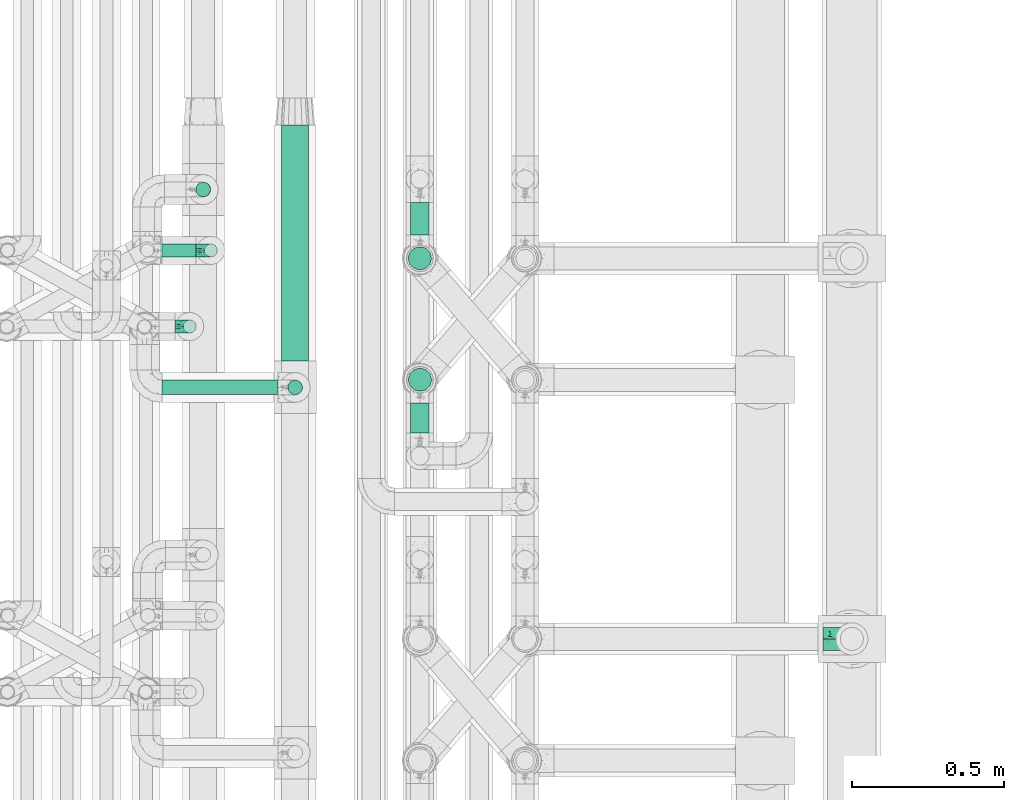
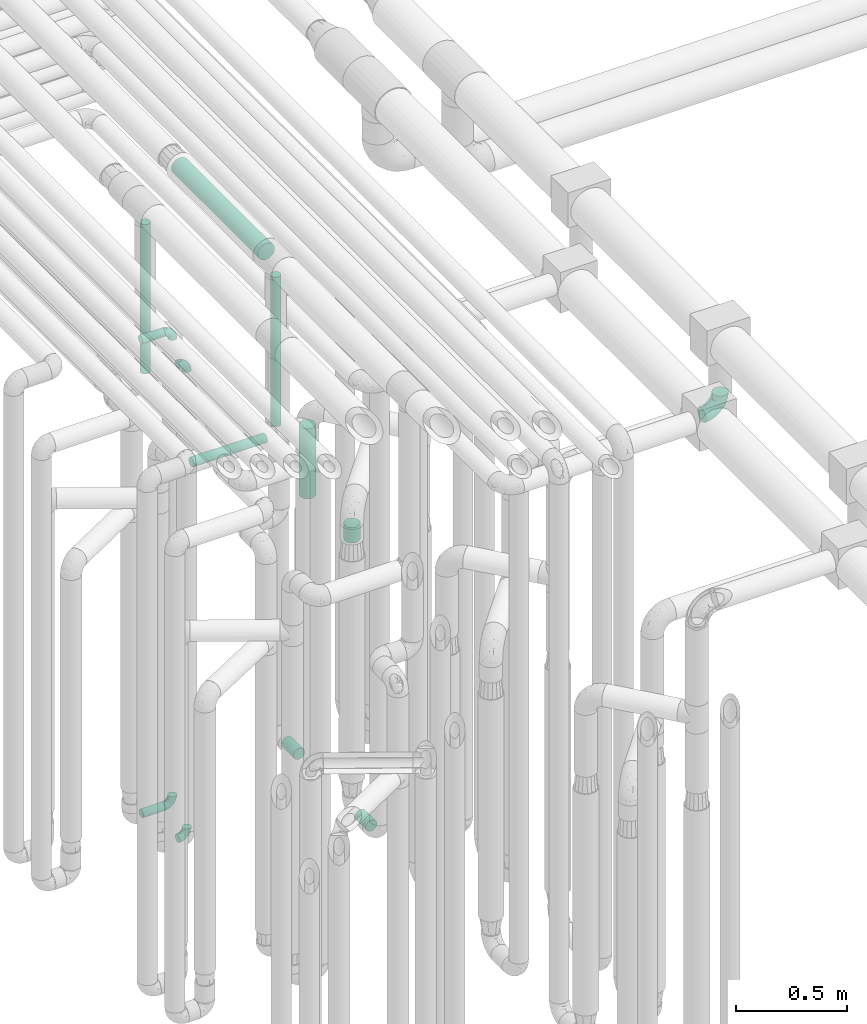
# One storey, part 622 of 827: 10 flow segments, 5 flow fittings.
"""IFC2X3 building model written with IfcOpenShell, lengths in millimetres."""

from ifc_helpers import new_model, entity, si_unit, converted_unit, derived_unit, direction, frame, origin, origin_2d_with_axis, place, context, subcontext, project, spatial, polyline, circle, outline, extrude, faceted_brep, source, transform, mapped, material, type_object, type_shapes, element, save


model = new_model("IFC2X3")

# Units and contexts
model_context = context("Model", 3, precision=0.01, world=origin(), true_north=direction((6.12303176911189e-17, 1.0)))
body_context = subcontext(model_context, "Body", "Model", "MODEL_VIEW")
ifc_project = project(units=[si_unit("LENGTHUNIT", "METRE", prefix="MILLI"), si_unit("AREAUNIT", "SQUARE_METRE"), si_unit("VOLUMEUNIT", "CUBIC_METRE"), converted_unit("PLANEANGLEUNIT", "DEGREE", entity("IfcRatioMeasure", 0.0174532925199433), si_unit("PLANEANGLEUNIT", "RADIAN"), dimensions=[0, 0, 0, 0, 0, 0, 0]), si_unit("MASSUNIT", "GRAM", prefix="KILO"), derived_unit("MASSDENSITYUNIT", [(si_unit("MASSUNIT", "GRAM", prefix="KILO"), 1), (si_unit("LENGTHUNIT", "METRE"), -3)]), derived_unit("MOMENTOFINERTIAUNIT", [(si_unit("LENGTHUNIT", "METRE"), 4)]), si_unit("TIMEUNIT", "SECOND"), si_unit("FREQUENCYUNIT", "HERTZ"), si_unit("THERMODYNAMICTEMPERATUREUNIT", "DEGREE_CELSIUS"), derived_unit("THERMALTRANSMITTANCEUNIT", [(si_unit("MASSUNIT", "GRAM", prefix="KILO"), 1), (si_unit("THERMODYNAMICTEMPERATUREUNIT", "KELVIN"), -1), (si_unit("TIMEUNIT", "SECOND"), -3)]), derived_unit("VOLUMETRICFLOWRATEUNIT", [(si_unit("LENGTHUNIT", "METRE"), 3), (si_unit("TIMEUNIT", "SECOND"), -1)]), derived_unit("MASSFLOWRATEUNIT", [(si_unit("MASSUNIT", "GRAM", prefix="KILO"), 1), (si_unit("TIMEUNIT", "SECOND"), -1)]), derived_unit("ROTATIONALFREQUENCYUNIT", [(si_unit("TIMEUNIT", "SECOND"), -1)]), si_unit("ELECTRICCURRENTUNIT", "AMPERE"), si_unit("ELECTRICVOLTAGEUNIT", "VOLT"), si_unit("POWERUNIT", "WATT"), si_unit("FORCEUNIT", "NEWTON", prefix="KILO"), si_unit("ILLUMINANCEUNIT", "LUX"), si_unit("LUMINOUSFLUXUNIT", "LUMEN"), si_unit("LUMINOUSINTENSITYUNIT", "CANDELA"), derived_unit("USERDEFINED", [(si_unit("MASSUNIT", "GRAM", prefix="KILO"), -1), (si_unit("LENGTHUNIT", "METRE"), -2), (si_unit("TIMEUNIT", "SECOND"), 3), (si_unit("LUMINOUSFLUXUNIT", "LUMEN"), 1)]), derived_unit("LINEARVELOCITYUNIT", [(si_unit("LENGTHUNIT", "METRE"), 1), (si_unit("TIMEUNIT", "SECOND"), -1)]), si_unit("PRESSUREUNIT", "PASCAL"), derived_unit("USERDEFINED", [(si_unit("LENGTHUNIT", "METRE"), -2), (si_unit("MASSUNIT", "GRAM", prefix="KILO"), 1), (si_unit("TIMEUNIT", "SECOND"), -2)]), derived_unit("LINEARFORCEUNIT", [(si_unit("MASSUNIT", "GRAM", prefix="KILO"), 1), (si_unit("LENGTHUNIT", "METRE"), 1), (si_unit("TIMEUNIT", "SECOND"), -2), (si_unit("LENGTHUNIT", "METRE"), -1)]), derived_unit("PLANARFORCEUNIT", [(si_unit("MASSUNIT", "GRAM", prefix="KILO"), 1), (si_unit("LENGTHUNIT", "METRE"), 1), (si_unit("TIMEUNIT", "SECOND"), -2), (si_unit("LENGTHUNIT", "METRE"), -2)])], contexts=[model_context])

# Site, building, storey
site_placement = place(None, origin())
site = spatial("IfcSite", under=ifc_project, at=site_placement, CompositionType="ELEMENT")
building_placement = place(site_placement, origin())
building = spatial("IfcBuilding", under=site, at=building_placement, CompositionType="ELEMENT")
storey_placement = place(building_placement, frame((0.0, 0.0, 28200.0)))
storey = spatial("IfcBuildingStorey", under=building, at=storey_placement, Name="08", CompositionType="ELEMENT", Elevation=28200.0)

# Flow segments
pipe_segment_type = type_object("IfcPipeSegmentType", PredefinedType="NOTDEFINED")
flow_segment_1_placement = place(storey_placement, frame((35782.14, 12983.46, 377.25)))
element("IfcFlowSegment", 1, at=flow_segment_1_placement, inside=storey, type_object=pipe_segment_type, context=body_context, shape_type="SweptSolid", body=[
    extrude(circle(Radius=21.15, at=origin_2d_with_axis()), frame((0.0, 22.75, 22.75), z_axis=(1.0, 0.0, 0.0), x_axis=(0.0, 1.0, 0.0)), (0.0, 0.0, 1.0), 112.906910281965),
])
flow_segment_2_placement = place(storey_placement, frame((35778.03, 12983.46, 2977.25)))
element("IfcFlowSegment", 2, at=flow_segment_2_placement, inside=storey, type_object=pipe_segment_type, context=body_context, shape_type="SweptSolid", body=[
    extrude(circle(Radius=21.15, at=origin_2d_with_axis()), frame((0.0, 22.75, 22.75), z_axis=(1.0, 0.0, 0.0), x_axis=(0.0, -1.0, 0.0)), (0.0, 0.0, 1.0), 117.013860377989),
])
flow_segment_3_placement = place(storey_placement, frame((36598.05, 13056.2, 368.4)))
element("IfcFlowSegment", 3, at=flow_segment_3_placement, inside=storey, type_object=pipe_segment_type, context=body_context, shape_type="SweptSolid", body=[
    extrude(circle(Radius=30.0, at=origin_2d_with_axis()), frame((31.6, 0.0, 31.6), z_axis=(0.0, 1.0, 0.0), x_axis=(-1.0, 0.0, 0.0)), (0.0, 0.0, 1.0), 108.00000000001),
])
flow_segment_4_placement = place(storey_placement, frame((36598.05, 12407.17, 368.4)))
element("IfcFlowSegment", 4, at=flow_segment_4_placement, inside=storey, type_object=pipe_segment_type, context=body_context, shape_type="SweptSolid", body=[
    extrude(circle(Radius=30.0, at=origin_2d_with_axis()), frame((31.6, 0.0, 31.6), z_axis=(0.0, 1.0, 0.0), x_axis=(1.0, 0.0, 0.0)), (0.0, 0.0, 1.0), 97.9999910000113),
])
flow_segment_5_placement = place(storey_placement, frame((36590.3, 12940.86, 1870.0)))
element("IfcFlowSegment", 5, at=flow_segment_5_placement, inside=storey, type_object=pipe_segment_type, context=body_context, shape_type="SweptSolid", body=[
    extrude(circle(Radius=37.75, at=origin_2d_with_axis()), frame((39.35, 39.35, 0.0)), (0.0, 0.0, 1.0), 384.999999999995),
])
flow_segment_6_placement = place(storey_placement, frame((36590.58, 12541.83, 1869.99)))
element("IfcFlowSegment", 6, at=flow_segment_6_placement, inside=storey, type_object=pipe_segment_type, context=body_context, shape_type="SweptSolid", body=[
    extrude(circle(Radius=37.75, at=origin_2d_with_axis()), frame((39.36, 39.35, 0.01), z_axis=(-0.000210996047409579, 0.0, 0.999999977740334), x_axis=(0.999999977740334, 0.0, 0.000210996047409579)), (0.0, 0.0, 1.0), 85.0000036990977),
])
flow_segment_7_placement = place(storey_placement, frame((35892.47, 13180.49, 2657.02)))
element("IfcFlowSegment", 7, at=flow_segment_7_placement, inside=storey, type_object=pipe_segment_type, context=body_context, shape_type="SweptSolid", body=[
    extrude(circle(Radius=24.0, at=origin_2d_with_axis()), frame((26.06, 25.6, 0.01), z_axis=(-0.000562863572107548, 0.0, 0.999999841592287), x_axis=(0.999999841592287, 0.0, 0.000562863572107548)), (0.0, 0.0, 1.0), 819.969793896105),
])
flow_segment_8_placement = place(storey_placement, frame((35782.03, 12530.49, 2574.4)))
element("IfcFlowSegment", 8, at=flow_segment_8_placement, inside=storey, type_object=pipe_segment_type, context=body_context, shape_type="SweptSolid", body=[
    extrude(circle(Radius=24.0, at=origin_2d_with_axis()), frame((0.0, 25.6, 25.6), z_axis=(1.0, 0.0, 0.0), x_axis=(0.0, -1.0, 0.0)), (0.0, 0.0, 1.0), 380.999999885415),
])
flow_segment_9_placement = place(storey_placement, frame((36194.44, 12530.49, 2657.0)))
element("IfcFlowSegment", 9, at=flow_segment_9_placement, inside=storey, type_object=pipe_segment_type, context=body_context, shape_type="SweptSolid", body=[
    extrude(outline(polyline([(-3.13, -23.79), (3.13, -23.79), (9.18, -22.17), (14.61, -19.04), (19.04, -14.61), (22.17, -9.18), (23.79, -3.13), (23.79, 3.13), (22.17, 9.18), (19.04, 14.61), (14.61, 19.04), (9.18, 22.17), (3.13, 23.79), (-3.13, 23.79), (-9.18, 22.17), (-14.61, 19.04), (-19.04, 14.61), (-22.17, 9.18), (-23.79, 3.13), (-23.79, -3.13), (-22.17, -9.18), (-19.04, -14.61), (-14.61, -19.04), (-9.18, -22.17), (-3.13, -23.79)])), frame((25.6, 25.6, 0.0), z_axis=(0.0, -8.11528883373535e-09, 1.0), x_axis=(-0.130526192219642, 0.991444861373864, 8.04589959840434e-09)), (0.0, 0.0, 1.0), 820.00007854167),
])
flow_segment_10_placement = place(storey_placement, frame((36174.19, 12642.08, 3504.15)))
element("IfcFlowSegment", 10, at=flow_segment_10_placement, inside=storey, type_object=pipe_segment_type, context=body_context, shape_type="SweptSolid", body=[
    extrude(circle(Radius=44.25, at=origin_2d_with_axis()), frame((45.85, 0.0, 45.85), z_axis=(0.0, 1.0, 0.0), x_axis=(-1.0, 0.0, 0.0)), (0.0, 0.0, 1.0), 775.619330449277),
])

# Flow fittings
ifc_material = material()
pipe_fitting_type_1 = type_object("IfcPipeFittingType", Name="ADSK_1", PredefinedType="NOTDEFINED", material=ifc_material)
shared_shape_1 = source(origin(), body_context, "Body", "Brep", [
    faceted_brep([(-48.0, 10.6, -18.36), (-48.0, 5.49, -20.48), (-48.0, 0.0, -21.2), (-48.0, -5.49, -20.48), (-48.0, -10.6, -18.36), (-48.0, -14.99, -14.99), (-48.0, -18.36, -10.6), (-48.0, -20.48, -5.49), (-48.0, -21.2, 0.0), (-48.0, -20.48, 5.49), (-48.0, -18.36, 10.6), (-48.0, -14.99, 14.99), (-48.0, -10.6, 18.36), (-48.0, -5.49, 20.48), (-48.0, 0.0, 21.2), (-48.0, 5.49, 20.48), (-48.0, 10.6, 18.36), (-48.0, 14.99, 14.99), (-48.0, 18.36, 10.6), (-48.0, 20.48, 5.49), (-48.0, 21.2, 0.0), (-48.0, 20.48, -5.49), (-48.0, 18.36, -10.6), (-48.0, 14.99, -14.99), (0.0, 48.0, -21.2), (-5.49, 48.0, -20.48), (-10.6, 48.0, -18.36), (-14.99, 48.0, -14.99), (-18.36, 48.0, -10.6), (-20.48, 48.0, -5.49), (-21.2, 48.0, 0.0), (-20.48, 48.0, 5.49), (-18.36, 48.0, 10.6), (-14.99, 48.0, 14.99), (-10.6, 48.0, 18.36), (-5.49, 48.0, 20.48), (0.0, 48.0, 21.2), (5.49, 48.0, 20.48), (10.6, 48.0, 18.36), (14.99, 48.0, 14.99), (18.36, 48.0, 10.6), (20.48, 48.0, 5.49), (21.2, 48.0, 0.0), (20.48, 48.0, -5.49), (18.36, 48.0, -10.6), (14.99, 48.0, -14.99), (10.6, 48.0, -18.36), (5.49, 48.0, -20.48), (-35.25, -16.22, 12.01), (-34.76, -18.57, 0.0), (-20.87, -12.37, 10.9), (-31.49, -11.78, 15.9), (-37.0, -2.58, 20.86), (-33.89, 3.62, 21.15), (-31.81, -18.14, 6.76), (-5.78, 5.78, 17.67), (-19.42, -4.1, 17.86), (-9.6, -3.39, 13.73), (-35.44, -7.73, 19.13), (11.78, 31.49, 15.9), (-5.93, -5.46, 6.95), (-18.45, -13.78, 5.46), (-10.29, -8.43, 0.0), (-24.6, 0.55, 20.62), (-37.28, 17.94, 13.81), (-33.38, 22.85, 9.59), (-41.46, 20.06, 8.75), (-29.51, 20.45, 15.16), (-15.04, 10.79, 21.13), (-7.08, 16.98, 20.93), (-8.39, 23.51, 21.15), (-40.86, 13.03, 17.26), (-8.05, 41.26, 19.83), (-3.21, 35.97, 21.14), (8.53, 19.66, 14.74), (4.1, 19.42, 17.86), (-37.72, 22.66, 4.78), (-37.07, 8.58, 19.98), (-13.0, 5.43, 19.97), (-3.78, 13.93, 19.7), (3.02, 8.69, 13.43), (-2.27, -0.05, 10.65), (6.22, 6.99, 7.09), (-22.25, 34.6, 9.45), (18.14, 31.81, 6.76), (16.22, 35.25, 12.01), (12.37, 20.87, 10.9), (7.73, 35.44, 19.13), (-21.52, -15.93, 0.0), (2.58, 37.0, 20.86), (18.57, 34.76, 0.0), (13.78, 18.45, 5.46), (15.93, 21.52, 0.0), (-20.03, -8.54, 14.9), (-28.6, 28.6, 5.16), (-24.79, 34.6, 0.0), (-34.6, 24.79, 0.0), (-22.81, 37.41, 4.68), (-23.36, 26.33, 14.79), (-13.68, 37.05, 17.49), (-17.72, 38.12, 13.73), (-26.25, 27.3, 11.24), (-9.71, 32.34, 20.14), (-17.26, 25.6, 18.71), (-26.33, 9.99, 20.77), (-24.06, 6.05, 21.2), (-25.02, 15.46, 19.56), (-24.3, 20.72, 17.57), (-31.95, 15.23, 17.8), (-13.53, 24.7, 20.21), (-17.6, 17.6, 20.6), (-0.55, 24.6, 20.62), (-11.41, -7.48, 10.43), (0.93, -0.93, 0.0), (8.43, 10.29, 0.0), (-11.41, -7.48, -10.43), (-20.1, -8.84, -14.66), (-9.6, -3.39, -13.73), (7.73, 35.44, -19.13), (4.1, 19.42, -17.86), (-0.55, 24.6, -20.62), (-38.12, 17.72, -13.73), (-37.05, 13.68, -17.49), (-32.34, 9.71, -20.14), (-41.26, 8.05, -19.83), (-37.41, 22.81, -4.68), (-23.51, 8.39, -21.15), (-35.97, 3.21, -21.14), (-28.6, 28.6, -5.16), (-31.81, -18.14, -6.76), (-18.45, -13.78, -5.46), (-25.6, 17.26, -18.71), (-19.42, -4.1, -17.86), (-17.94, 37.28, -13.81), (-22.85, 33.38, -9.59), (-20.06, 41.46, -8.75), (-31.49, -11.78, -15.9), (-35.25, -16.22, -12.01), (8.53, 19.66, -14.74), (11.78, 31.49, -15.9), (-9.99, 26.33, -20.77), (-6.05, 24.06, -21.2), (-10.79, 15.04, -21.13), (-37.0, -2.58, -20.86), (-16.98, 7.08, -20.93), (-5.43, 13.0, -19.97), (-13.93, 3.78, -19.7), (-20.87, -12.37, -10.9), (-26.33, 23.36, -14.79), (-22.66, 37.72, -4.78), (13.78, 18.45, -5.46), (18.14, 31.81, -6.76), (-15.46, 25.02, -19.56), (-20.72, 24.3, -17.57), (16.22, 35.25, -12.01), (-13.03, 40.86, -17.26), (-8.58, 37.07, -19.98), (2.58, 37.0, -20.86), (-3.62, 33.89, -21.15), (-34.6, 22.25, -9.45), (6.22, 6.99, -7.09), (-20.45, 29.51, -15.16), (-35.44, -7.73, -19.13), (12.37, 20.87, -10.9), (-27.3, 26.25, -11.24), (-15.23, 31.95, -17.8), (-24.7, 13.53, -20.21), (-24.6, 0.55, -20.62), (-5.78, 5.78, -17.67), (-17.6, 17.6, -20.6), (3.02, 8.69, -13.43), (-5.93, -5.46, -6.95), (-2.27, -0.05, -10.65)], [[[0, 1, 2, 3, 4, 5, 6, 7, 8, 9, 10, 11, 12, 13, 14, 15, 16, 17, 18, 19, 20, 21, 22, 23]], [[24, 25, 26, 27, 28, 29, 30, 31, 32, 33, 34, 35, 36, 37, 38, 39, 40, 41, 42, 43, 44, 45, 46, 47]], [[10, 48, 11]], [[9, 8, 49]], [[48, 50, 51]], [[14, 52, 53]], [[10, 54, 48]], [[9, 54, 10]], [[55, 56, 57]], [[51, 12, 11]], [[51, 58, 12]], [[59, 39, 38]], [[60, 61, 62]], [[58, 56, 63]], [[64, 65, 66]], [[67, 65, 64]], [[68, 69, 70]], [[16, 71, 17]], [[13, 52, 14]], [[35, 72, 73]], [[14, 53, 15]], [[17, 64, 18]], [[74, 59, 75]], [[20, 19, 76]], [[66, 19, 18]], [[77, 15, 53]], [[15, 77, 16]], [[69, 78, 79]], [[80, 81, 82]], [[32, 31, 83]], [[84, 85, 86]], [[59, 87, 75]], [[61, 54, 88]], [[36, 89, 37]], [[84, 41, 40]], [[36, 35, 73]], [[90, 41, 84]], [[40, 39, 85]], [[12, 58, 13]], [[85, 84, 40]], [[91, 84, 86]], [[84, 92, 90]], [[87, 38, 37]], [[93, 56, 51]], [[65, 94, 76]], [[94, 95, 96]], [[84, 91, 92]], [[95, 97, 30]], [[98, 99, 100]], [[76, 94, 96]], [[101, 98, 83]], [[100, 99, 33]], [[102, 70, 73]], [[103, 102, 99]], [[94, 97, 95]], [[72, 99, 102]], [[72, 35, 34]], [[34, 33, 99]], [[9, 49, 54]], [[87, 59, 38]], [[104, 105, 68]], [[106, 103, 107]], [[106, 77, 104]], [[71, 64, 17]], [[108, 107, 67]], [[33, 32, 100]], [[109, 103, 110]], [[102, 109, 70]], [[89, 73, 111]], [[50, 48, 54]], [[51, 11, 48]], [[56, 58, 51]], [[88, 54, 49]], [[52, 58, 63]], [[50, 112, 93]], [[56, 55, 78]], [[39, 59, 85]], [[86, 85, 59]], [[89, 87, 37]], [[42, 41, 90]], [[111, 79, 75]], [[111, 75, 87]], [[75, 55, 80]], [[104, 77, 53]], [[71, 77, 108]], [[32, 83, 100]], [[98, 100, 83]], [[99, 98, 103]], [[106, 107, 108]], [[68, 70, 110]], [[111, 73, 70]], [[68, 110, 104]], [[68, 63, 78]], [[57, 93, 112]], [[80, 55, 57]], [[61, 50, 54]], [[80, 82, 86]], [[81, 57, 112]], [[74, 86, 59]], [[60, 113, 82]], [[82, 114, 91]], [[101, 94, 65]], [[97, 94, 83]], [[73, 89, 36]], [[87, 89, 111]], [[58, 52, 13]], [[53, 52, 63]], [[104, 53, 105]], [[106, 104, 110]], [[20, 76, 96]], [[76, 19, 66]], [[103, 106, 110]], [[77, 106, 108]], [[103, 98, 107]], [[67, 107, 98]], [[67, 98, 101]], [[108, 67, 64]], [[53, 63, 105]], [[63, 68, 105]], [[83, 31, 97]], [[30, 97, 31]], [[62, 113, 60]], [[112, 61, 60]], [[61, 88, 62]], [[86, 82, 91]], [[56, 78, 63]], [[114, 82, 113]], [[114, 92, 91]], [[79, 78, 55]], [[75, 79, 55]], [[69, 79, 111]], [[70, 69, 111]], [[78, 69, 68]], [[77, 71, 16]], [[64, 71, 108]], [[64, 66, 18]], [[76, 66, 65]], [[99, 72, 34]], [[73, 72, 102]], [[94, 101, 83]], [[67, 101, 65]], [[75, 80, 74]], [[80, 86, 74]], [[70, 109, 110]], [[102, 103, 109]], [[50, 93, 51]], [[57, 56, 93]], [[61, 112, 50]], [[81, 112, 60]], [[82, 81, 60]], [[80, 57, 81]], [[115, 116, 117]], [[118, 119, 120]], [[121, 122, 23]], [[123, 124, 122]], [[96, 125, 20]], [[123, 126, 127]], [[128, 96, 95]], [[129, 130, 88]], [[123, 122, 131]], [[116, 132, 117]], [[133, 134, 135]], [[0, 124, 1]], [[5, 136, 137]], [[138, 119, 139]], [[129, 88, 49]], [[140, 141, 142]], [[6, 5, 137]], [[46, 118, 47]], [[143, 3, 2]], [[144, 145, 146]], [[6, 129, 7]], [[129, 137, 147]], [[127, 2, 1]], [[148, 122, 121]], [[128, 125, 96]], [[134, 128, 149]], [[95, 149, 128]], [[150, 151, 92]], [[30, 29, 149]], [[152, 131, 153]], [[27, 133, 28]], [[154, 45, 44]], [[136, 5, 4]], [[27, 26, 155]], [[156, 26, 25]], [[24, 157, 158]], [[24, 47, 157]], [[22, 21, 159]], [[160, 150, 114]], [[134, 133, 161]], [[142, 144, 126]], [[46, 139, 118]], [[162, 136, 4]], [[156, 25, 158]], [[1, 124, 127]], [[115, 147, 116]], [[45, 154, 139]], [[139, 46, 45]], [[154, 163, 139]], [[162, 4, 3]], [[42, 90, 43]], [[130, 129, 147]], [[49, 7, 129]], [[43, 151, 44]], [[0, 23, 122]], [[24, 158, 25]], [[136, 162, 132]], [[135, 29, 28]], [[43, 90, 151]], [[164, 148, 159]], [[152, 156, 140]], [[155, 133, 27]], [[165, 153, 161]], [[23, 22, 121]], [[123, 131, 166]], [[123, 166, 126]], [[143, 127, 167]], [[147, 137, 136]], [[8, 7, 49]], [[129, 6, 137]], [[143, 162, 3]], [[167, 146, 132]], [[167, 132, 162]], [[132, 168, 117]], [[44, 151, 154]], [[92, 151, 90]], [[163, 154, 151]], [[119, 118, 139]], [[157, 118, 120]], [[138, 139, 163]], [[119, 168, 145]], [[140, 156, 158]], [[155, 156, 165]], [[22, 159, 121]], [[148, 121, 159]], [[122, 148, 131]], [[152, 153, 165]], [[142, 126, 169]], [[167, 127, 126]], [[142, 169, 140]], [[142, 120, 145]], [[168, 170, 117]], [[160, 171, 172]], [[115, 172, 171]], [[171, 62, 130]], [[119, 170, 168]], [[170, 163, 160]], [[150, 163, 151]], [[113, 171, 160]], [[164, 128, 134]], [[125, 128, 159]], [[127, 143, 2]], [[162, 143, 167]], [[118, 157, 47]], [[158, 157, 120]], [[140, 158, 141]], [[152, 140, 169]], [[30, 149, 95]], [[149, 29, 135]], [[131, 152, 169]], [[156, 152, 165]], [[131, 148, 153]], [[161, 153, 148]], [[161, 148, 164]], [[165, 161, 133]], [[158, 120, 141]], [[120, 142, 141]], [[159, 21, 125]], [[20, 125, 21]], [[115, 130, 147]], [[114, 113, 160]], [[62, 171, 113]], [[62, 88, 130]], [[160, 163, 150]], [[150, 92, 114]], [[119, 145, 120]], [[146, 145, 168]], [[132, 146, 168]], [[144, 146, 167]], [[126, 144, 167]], [[145, 144, 142]], [[156, 155, 26]], [[133, 155, 165]], [[133, 135, 28]], [[149, 135, 134]], [[122, 124, 0]], [[127, 124, 123]], [[128, 164, 159]], [[161, 164, 134]], [[163, 170, 138]], [[170, 119, 138]], [[131, 169, 166]], [[126, 166, 169]], [[147, 136, 116]], [[132, 116, 136]], [[172, 115, 117]], [[130, 115, 171]], [[117, 170, 172]], [[160, 172, 170]]]),
])
type_shapes(pipe_fitting_type_1, [shared_shape_1])
for number, where, z_axis, x_axis, name in (
    (11, (35873.78, 12756.17, 3000.0), (0.0, 1.0, 0.0), (1.0, 0.0, 0.0), "ADSK_1"),
    (12, (35873.78, 12756.17, 400.0), (0.0, 1.0, 0.0), (0.0, 0.0, -1.0), "ADSK_1"),
    (13, (35943.05, 13006.2, 3000.0), (0.0, 1.0, 0.0), (1.0, 0.0, 0.0), "ADSK_1"),
    (14, (35943.05, 13006.2, 400.0), (0.0, -1.0, 0.0), (1.0, 0.0, 0.0), "ADSK_1"),
):
    element("IfcFlowFitting", number, at=place(storey_placement, frame(where, z_axis=z_axis, x_axis=x_axis)), inside=storey, type_object=pipe_fitting_type_1, material=ifc_material, Name=name, ObjectType="ADSK_1", context=body_context, shape_type="MappedRepresentation", body=[
        mapped(shared_shape_1, transform((0.0, 0.0, 0.0), scale=1.0)),
    ])
pipe_fitting_type_2 = type_object("IfcPipeFittingType", Name="ADSK_1", PredefinedType="NOTDEFINED", material=ifc_material)
shared_shape_2 = source(origin(), body_context, "Body", "Brep", [
    faceted_brep([(-95.0, 19.02, -32.95), (-95.0, 9.85, -36.75), (-95.0, 0.0, -38.05), (-95.0, -9.85, -36.75), (-95.0, -19.03, -32.95), (-95.0, -26.91, -26.91), (-95.0, -32.95, -19.03), (-95.0, -36.75, -9.85), (-95.0, -38.05, 0.0), (-95.0, -36.75, 9.85), (-95.0, -32.95, 19.02), (-95.0, -26.91, 26.91), (-95.0, -19.03, 32.95), (-95.0, -9.85, 36.75), (-95.0, 0.0, 38.05), (-95.0, 9.85, 36.75), (-95.0, 19.02, 32.95), (-95.0, 26.91, 26.91), (-95.0, 32.95, 19.02), (-95.0, 36.75, 9.85), (-95.0, 38.05, 0.0), (-95.0, 36.75, -9.85), (-95.0, 32.95, -19.03), (-95.0, 26.91, -26.91), (0.0, 95.0, -38.05), (-9.85, 95.0, -36.75), (-19.02, 95.0, -32.95), (-26.91, 95.0, -26.91), (-32.95, 95.0, -19.03), (-36.75, 95.0, -9.85), (-38.05, 95.0, 0.0), (-36.75, 95.0, 9.85), (-32.95, 95.0, 19.02), (-26.91, 95.0, 26.91), (-19.02, 95.0, 32.95), (-9.85, 95.0, 36.75), (0.0, 95.0, 38.05), (9.85, 95.0, 36.75), (19.03, 95.0, 32.95), (26.91, 95.0, 26.91), (32.95, 95.0, 19.02), (36.75, 95.0, 9.85), (38.05, 95.0, 0.0), (36.75, 95.0, -9.85), (32.95, 95.0, -19.03), (26.91, 95.0, -26.91), (19.03, 95.0, -32.95), (9.85, 95.0, -36.75), (-7.99, -4.96, 6.3), (-0.92, 0.92, 0.0), (4.62, 8.1, 8.01), (-76.19, -35.57, 0.0), (-64.32, -32.32, 12.43), (20.51, 62.45, 28.68), (-60.56, -33.52, 0.0), (-70.4, -13.47, 34.42), (-39.61, -5.88, 32.32), (-49.6, 2.07, 37.1), (-70.34, -28.81, 21.71), (14.64, 40.81, 26.5), (5.88, 39.61, 32.32), (3.59, 20.77, 25.31), (-40.45, 68.06, 16.75), (-62.45, -20.51, 28.68), (-44.52, -26.87, 0.0), (-28.47, -20.22, 0.0), (-26.43, -17.83, 8.75), (-76.1, 39.63, 10.76), (-72.74, 37.58, 18.19), (-60.35, 46.18, 14.61), (-13.4, 13.4, 32.12), (-20.77, -3.59, 25.31), (-14.66, 81.47, 35.56), (-6.22, 71.26, 37.92), (-57.5, 42.48, 22.79), (-15.0, 34.74, 37.7), (-27.1, 12.08, 36.05), (-9.2, 28.81, 35.63), (-79.98, 23.7, 30.95), (-73.68, -4.3, 37.48), (-30.74, 21.67, 37.97), (-62.36, 47.59, 6.79), (-72.71, 32.83, 24.69), (-67.42, 7.02, 37.95), (-32.13, 75.27, 24.51), (-43.46, 51.47, 26.26), (-24.98, 73.15, 31.29), (20.59, 41.28, 19.85), (7.79, 16.09, 15.86), (-73.21, 42.39, 0.0), (-54.73, 54.73, 0.0), (-73.44, 15.79, 35.79), (-5.94, 4.32, 20.43), (28.81, 70.34, 21.71), (32.32, 64.32, 12.43), (-53.59, 26.2, 35.09), (-52.02, 19.31, 37.21), (21.38, 33.53, 10.34), (26.87, 44.52, 0.0), (-48.28, 12.14, 38.05), (4.3, 73.68, 37.48), (-44.08, -25.52, 12.79), (-41.28, -20.59, 19.85), (35.57, 76.19, 0.0), (-47.26, 54.3, 20.18), (-47.4, 61.99, 8.58), (-42.39, 73.21, 0.0), (-39.67, 78.86, 7.21), (-45.69, 36.84, 33.11), (-32.83, 50.13, 33.35), (13.47, 70.4, 34.42), (-18.25, 63.73, 36.07), (-40.63, -13.75, 27.22), (-16.63, 46.37, 37.95), (-53.47, 38.79, 28.59), (-26.07, 48.54, 36.15), (-34.51, 34.51, 36.86), (-2.07, 49.6, 37.1), (-22.79, -10.49, 19.23), (-61.73, 28.67, 31.87), (9.65, 14.7, 0.0), (20.22, 28.47, 0.0), (33.52, 60.56, 0.0), (-11.42, -5.44, 13.25), (-14.7, -9.65, 0.0), (-81.47, 14.66, -35.56), (-62.45, -20.51, -28.68), (-71.26, 6.22, -37.92), (-75.27, 32.13, -24.51), (-73.15, 24.98, -31.29), (13.47, 70.4, -34.42), (5.88, 39.61, -32.32), (-2.07, 49.6, -37.1), (-78.86, 39.67, -7.21), (-70.4, -13.47, -34.42), (-39.61, -5.88, -32.32), (-61.99, 47.4, -8.58), (32.32, 64.32, -12.43), (28.81, 70.34, -21.71), (-63.73, 18.25, -36.07), (-50.13, 32.83, -33.35), (4.3, 73.68, -37.48), (-7.02, 67.42, -37.95), (-39.63, 76.1, -10.76), (-46.18, 60.35, -14.61), (-47.59, 62.36, -6.79), (-64.32, -32.32, -12.43), (-26.2, 53.59, -35.09), (-15.79, 73.44, -35.79), (-19.31, 52.02, -37.21), (-37.58, 72.74, -18.19), (-70.34, -28.81, -21.71), (-42.48, 57.5, -22.79), (-38.79, 53.47, -28.59), (-51.47, 43.46, -26.26), (-32.83, 72.71, -24.69), (-46.37, 16.63, -37.95), (-73.68, -4.3, -37.48), (-41.28, -20.59, -19.85), (-44.08, -25.52, -12.79), (13.75, 40.63, -27.22), (20.51, 62.45, -28.68), (-68.06, 40.45, -16.75), (-54.3, 47.26, -20.18), (-12.14, 48.28, -38.05), (-21.67, 30.74, -37.97), (-36.84, 45.69, -33.11), (-11.42, -5.44, -13.25), (7.79, 16.09, -15.86), (4.62, 8.1, -8.01), (-23.7, 79.98, -30.95), (-26.43, -17.83, -8.75), (-7.99, -4.96, -6.3), (-40.81, -14.64, -26.5), (-20.77, -3.59, -25.31), (-34.74, 15.0, -37.7), (-12.08, 27.1, -36.05), (-28.81, 9.2, -35.63), (-22.79, -10.49, -19.23), (21.38, 33.53, -10.34), (20.59, 41.28, -19.85), (-48.54, 26.07, -36.15), (-49.6, 2.07, -37.1), (-13.4, 13.4, -32.12), (3.59, 20.77, -25.31), (-28.67, 61.73, -31.87), (-34.51, 34.51, -36.86), (-5.94, 4.32, -20.43)], [[[0, 1, 2, 3, 4, 5, 6, 7, 8, 9, 10, 11, 12, 13, 14, 15, 16, 17, 18, 19, 20, 21, 22, 23]], [[24, 25, 26, 27, 28, 29, 30, 31, 32, 33, 34, 35, 36, 37, 38, 39, 40, 41, 42, 43, 44, 45, 46, 47]], [[48, 49, 50]], [[51, 52, 9]], [[53, 39, 38]], [[9, 52, 10]], [[54, 52, 51]], [[55, 56, 57]], [[11, 10, 58]], [[59, 60, 61]], [[32, 31, 62]], [[63, 12, 11]], [[63, 55, 12]], [[64, 65, 66]], [[67, 68, 69]], [[70, 56, 71]], [[35, 72, 73]], [[69, 68, 74]], [[75, 76, 77]], [[16, 78, 17]], [[13, 79, 14]], [[76, 75, 80]], [[67, 69, 81]], [[18, 17, 82]], [[14, 79, 83]], [[20, 19, 67]], [[84, 85, 86]], [[87, 61, 88]], [[89, 81, 90]], [[18, 82, 68]], [[15, 91, 16]], [[14, 83, 15]], [[71, 92, 61]], [[17, 78, 82]], [[93, 87, 94]], [[95, 91, 96]], [[97, 98, 94]], [[86, 72, 34]], [[96, 99, 80]], [[37, 36, 100]], [[40, 39, 93]], [[40, 94, 41]], [[64, 66, 101]], [[93, 94, 40]], [[58, 102, 63]], [[94, 103, 41]], [[94, 87, 97]], [[104, 69, 74]], [[34, 33, 86]], [[105, 69, 104]], [[52, 58, 10]], [[106, 107, 30]], [[108, 109, 85]], [[105, 106, 90]], [[53, 110, 60]], [[86, 111, 72]], [[86, 109, 111]], [[33, 84, 86]], [[12, 55, 13]], [[112, 56, 63]], [[110, 38, 37]], [[34, 72, 35]], [[36, 35, 73]], [[111, 113, 73]], [[105, 107, 106]], [[110, 53, 38]], [[74, 114, 85]], [[91, 15, 83]], [[105, 90, 81]], [[107, 62, 31]], [[33, 32, 84]], [[115, 109, 116]], [[111, 115, 113]], [[100, 73, 117]], [[56, 55, 63]], [[79, 55, 57]], [[102, 118, 112]], [[56, 70, 76]], [[100, 110, 37]], [[117, 77, 60]], [[117, 60, 110]], [[60, 70, 61]], [[58, 52, 101]], [[63, 11, 58]], [[39, 53, 93]], [[87, 93, 53]], [[96, 91, 83]], [[78, 91, 119]], [[32, 62, 84]], [[84, 62, 104]], [[86, 85, 109]], [[85, 114, 108]], [[80, 113, 116]], [[117, 73, 113]], [[80, 116, 96]], [[80, 57, 76]], [[71, 112, 118]], [[61, 87, 59]], [[62, 107, 105]], [[97, 120, 121]], [[70, 71, 61]], [[71, 118, 92]], [[73, 100, 36]], [[110, 100, 117]], [[55, 79, 13]], [[83, 79, 57]], [[96, 83, 99]], [[116, 108, 95]], [[50, 97, 88]], [[97, 87, 88]], [[50, 49, 120]], [[122, 94, 98]], [[89, 20, 67]], [[105, 81, 69]], [[89, 67, 81]], [[68, 19, 18]], [[68, 67, 19]], [[74, 68, 82]], [[114, 82, 119]], [[74, 85, 104]], [[82, 114, 74]], [[114, 119, 108]], [[95, 108, 119]], [[116, 109, 108]], [[123, 48, 50]], [[97, 50, 120]], [[123, 50, 88]], [[91, 95, 119]], [[116, 95, 96]], [[84, 104, 85]], [[104, 62, 105]], [[83, 57, 99]], [[57, 80, 99]], [[66, 48, 123]], [[66, 124, 48]], [[118, 66, 123]], [[124, 66, 65]], [[66, 118, 101]], [[54, 64, 52]], [[124, 49, 48]], [[30, 107, 31]], [[91, 78, 16]], [[82, 78, 119]], [[56, 76, 57]], [[77, 76, 70]], [[60, 77, 70]], [[77, 117, 75]], [[117, 113, 75]], [[113, 80, 75]], [[9, 8, 51]], [[103, 94, 122]], [[103, 42, 41]], [[73, 72, 111]], [[113, 115, 116]], [[111, 109, 115]], [[102, 112, 63]], [[71, 56, 112]], [[118, 102, 101]], [[92, 123, 88]], [[123, 92, 118]], [[61, 92, 88]], [[87, 53, 59]], [[60, 59, 53]], [[97, 121, 98]], [[58, 101, 102]], [[64, 101, 52]], [[125, 1, 0]], [[126, 5, 4]], [[2, 1, 127]], [[1, 125, 127]], [[128, 129, 23]], [[130, 131, 132]], [[89, 133, 20]], [[126, 134, 135]], [[136, 89, 90]], [[137, 138, 44]], [[139, 129, 140]], [[24, 141, 142]], [[143, 144, 145]], [[125, 129, 139]], [[6, 146, 7]], [[147, 148, 149]], [[146, 51, 7]], [[143, 150, 144]], [[146, 6, 151]], [[152, 153, 154]], [[126, 4, 134]], [[0, 23, 129]], [[28, 155, 150]], [[43, 42, 103]], [[54, 146, 64]], [[139, 156, 127]], [[157, 3, 2]], [[151, 158, 159]], [[160, 131, 161]], [[22, 21, 162]], [[136, 144, 163]], [[149, 164, 165]], [[24, 142, 25]], [[166, 140, 154]], [[154, 129, 128]], [[143, 30, 29]], [[167, 168, 169]], [[155, 28, 27]], [[26, 170, 27]], [[171, 167, 172]], [[26, 25, 148]], [[27, 170, 155]], [[173, 135, 174]], [[144, 150, 152]], [[175, 176, 177]], [[24, 47, 141]], [[45, 161, 46]], [[148, 25, 142]], [[176, 175, 165]], [[64, 159, 171]], [[138, 45, 44]], [[130, 46, 161]], [[137, 44, 43]], [[178, 159, 158]], [[137, 103, 122]], [[163, 144, 152]], [[136, 133, 89]], [[103, 137, 43]], [[6, 5, 151]], [[178, 158, 173]], [[134, 4, 3]], [[178, 173, 174]], [[137, 98, 179]], [[145, 90, 106]], [[138, 180, 161]], [[46, 130, 47]], [[136, 90, 145]], [[133, 162, 21]], [[23, 22, 128]], [[139, 140, 181]], [[139, 181, 156]], [[157, 127, 182]], [[157, 134, 3]], [[182, 177, 135]], [[182, 135, 134]], [[135, 183, 174]], [[131, 130, 161]], [[141, 130, 132]], [[160, 180, 184]], [[131, 183, 176]], [[5, 126, 151]], [[158, 151, 126]], [[180, 138, 137]], [[161, 45, 138]], [[149, 148, 142]], [[170, 148, 185]], [[22, 162, 128]], [[128, 162, 163]], [[129, 154, 140]], [[154, 153, 166]], [[165, 156, 186]], [[182, 127, 156]], [[165, 186, 149]], [[165, 132, 176]], [[131, 184, 183]], [[187, 167, 178]], [[184, 168, 187]], [[167, 169, 172]], [[184, 180, 168]], [[174, 183, 184]], [[127, 157, 2]], [[134, 157, 182]], [[130, 141, 47]], [[142, 141, 132]], [[149, 142, 164]], [[186, 166, 147]], [[180, 179, 168]], [[169, 179, 120]], [[137, 179, 180]], [[179, 121, 120]], [[106, 30, 143]], [[136, 145, 144]], [[106, 143, 145]], [[150, 29, 28]], [[150, 143, 29]], [[152, 150, 155]], [[153, 155, 185]], [[152, 154, 163]], [[155, 153, 152]], [[153, 185, 166]], [[147, 166, 185]], [[186, 140, 166]], [[169, 120, 49]], [[169, 49, 172]], [[179, 169, 168]], [[148, 147, 185]], [[186, 147, 149]], [[128, 163, 154]], [[163, 162, 136]], [[142, 132, 164]], [[132, 165, 164]], [[171, 124, 65]], [[124, 171, 172]], [[64, 146, 159]], [[171, 159, 178]], [[171, 65, 64]], [[172, 49, 124]], [[162, 133, 136]], [[20, 133, 21]], [[148, 170, 26]], [[155, 170, 185]], [[131, 176, 132]], [[177, 176, 183]], [[135, 177, 183]], [[177, 182, 175]], [[182, 156, 175]], [[156, 165, 175]], [[51, 146, 54]], [[51, 8, 7]], [[129, 125, 0]], [[127, 125, 139]], [[140, 186, 181]], [[156, 181, 186]], [[158, 126, 173]], [[135, 173, 126]], [[187, 178, 174]], [[171, 178, 167]], [[184, 187, 174]], [[167, 187, 168]], [[180, 160, 161]], [[184, 131, 160]], [[98, 137, 122]], [[98, 121, 179]], [[151, 159, 146]]]),
])
type_shapes(pipe_fitting_type_2, [shared_shape_2])
flow_fitting_placement = place(storey_placement, frame((38048.3, 11730.2, 2600.0), z_axis=(0.0, 1.0, 0.0), x_axis=(0.0, 0.0, -1.0)))
element("IfcFlowFitting", 15, at=flow_fitting_placement, inside=storey, type_object=pipe_fitting_type_2, material=ifc_material, Name="ADSK_1", ObjectType="ADSK_1", context=body_context, shape_type="MappedRepresentation", body=[
    mapped(shared_shape_2, transform((0.0, 0.0, 0.0), scale=1.0)),
])

save(model, "model.ifc")
